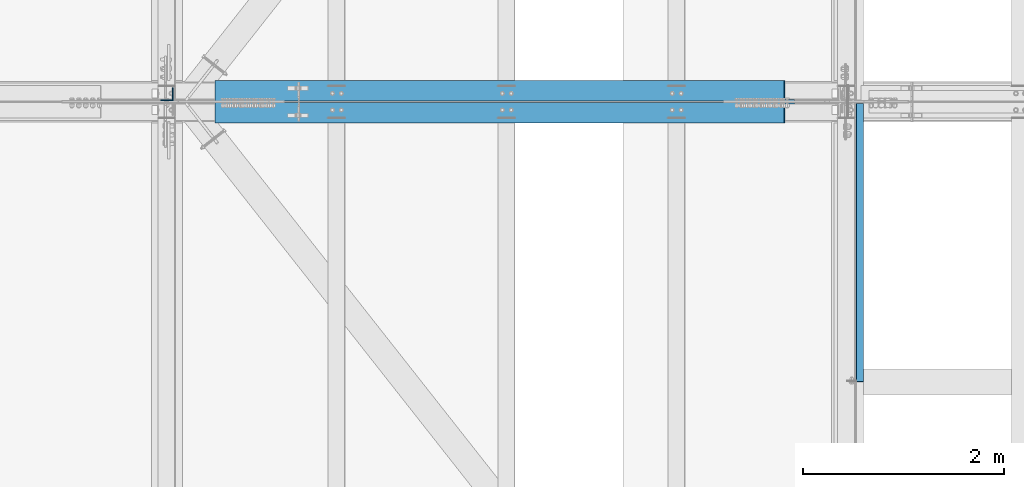
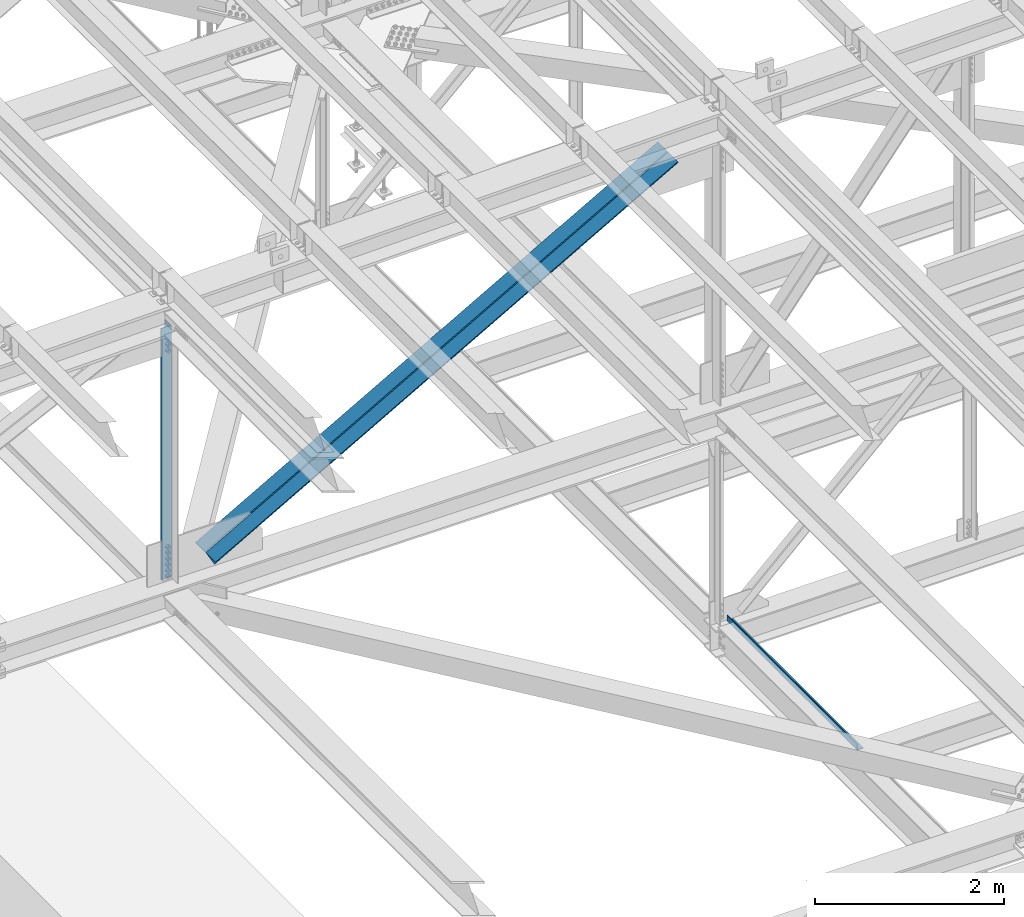
# One storey, part 1900 of 3843: 2 beams, 2 members, 4 elements without a shape of their own.
"""IFC2X3 building model written with IfcOpenShell, lengths in millimetres."""

from ifc_helpers import new_model, si_unit, frame, origin_with_axes, place, context, subcontext, project, spatial, faceted_brep, material, type_object, element, aggregate, save


model = new_model("IFC2X3")

# Units and contexts
model_context = context("Model", 3, precision=1e-05, world=origin_with_axes())
body_context = subcontext(model_context, "Body", "Model", "MODEL_VIEW")
ifc_project = project(units=[si_unit("LENGTHUNIT", "METRE", prefix="MILLI"), si_unit("AREAUNIT", "SQUARE_METRE"), si_unit("VOLUMEUNIT", "CUBIC_METRE"), si_unit("MASSUNIT", "GRAM", prefix="KILO"), si_unit("TIMEUNIT", "SECOND"), si_unit("PLANEANGLEUNIT", "RADIAN"), si_unit("SOLIDANGLEUNIT", "STERADIAN"), si_unit("THERMODYNAMICTEMPERATUREUNIT", "DEGREE_CELSIUS"), si_unit("LUMINOUSINTENSITYUNIT", "LUMEN")], contexts=[model_context])

# Site, building, storey
site_placement = place(None, origin_with_axes())
site = spatial("IfcSite", under=ifc_project, at=site_placement, CompositionType="ELEMENT")
building_placement = place(site_placement, origin_with_axes())
building = spatial("IfcBuilding", under=site, at=building_placement, Name="Undefined", CompositionType="ELEMENT")
storey_placement = place(building_placement, origin_with_axes())
storey = spatial("IfcBuildingStorey", under=building, at=storey_placement, Name="Undefined", CompositionType="ELEMENT", Elevation=0.0)

# Assembly, beam
assembly_1_placement = place(storey_placement, origin_with_axes())
assembly_1 = element("IfcElementAssembly", 1, at=assembly_1_placement, inside=storey, Name="BENT_PLATE", AssemblyPlace="NOTDEFINED", PredefinedType="RIGID_FRAME")
ifc_material_1 = material(Name="STEEL/A36")
beam_type_1 = type_object("IfcBeamType", PredefinedType="NOTDEFINED")
beam_1_placement = place(assembly_1_placement, frame((77179.4875000007, 65869.34475, 39627.1749999995), z_axis=(0.0, 1.0, 0.0), x_axis=(-1.0, 0.0, 0.0)))
beam_1 = element("IfcBeam", 2, at=beam_1_placement, type_object=beam_type_1, material=ifc_material_1, Name="BENT_PLATE", context=body_context, shape_type="Brep", body=[
    faceted_brep([(73.0250000006927, 0.0, -1382.7135), (69.8500000005442, 3.17500000000291, -1379.53850000001), (69.850000000617, 73.0249999994776, -1379.53850000001), (73.02500000078, 73.0249999994703, -1382.71249999999), (0.0, -7.27595761418343e-12, -1382.71249999999), (0.0, 3.17500000000291, -1379.53850000001), (69.8500000005442, 3.17500000000291, 1382.71249999999), (0.0, 3.17500000000291, 1382.71249999999), (0.0, -3.17500000000291, 1382.71249999999), (76.2000000005355, -3.17500000000291, 1382.71249999999), (76.2000000006228, 73.024999999463, 1382.71249999999), (69.850000000617, 73.0249999994776, 1382.71249999999), (0.0, -3.17500000000291, -1382.71249999999), (76.2000000005355, -3.17500000000291, -1382.71249999999), (76.2000000006228, 73.024999999463, -1382.71249999999)], [[[0, 1, 2, 3]], [[4, 5, 1, 0]], [[6, 7, 8, 9, 10, 11]], [[8, 12, 13, 9]], [[9, 13, 14, 10]], [[11, 10, 14, 3, 2]], [[6, 11, 2, 1]], [[7, 6, 1, 5]], [[12, 8, 7, 5, 4]], [[14, 13, 12, 4, 0, 3]]]),
])
aggregate(assembly_1, [beam_1])

assembly_2_placement = place(storey_placement, origin_with_axes())
assembly_2 = element("IfcElementAssembly", 3, at=assembly_2_placement, inside=storey, Name="ANGLE", AssemblyPlace="NOTDEFINED", PredefinedType="RIGID_FRAME")
ifc_material_2 = material(Name="STEEL/A572-50")
beam_type_2 = type_object("IfcBeamType", Name="L5X5X3/8", PredefinedType="NOTDEFINED")
beam_2_placement = place(assembly_2_placement, frame((70256.4000000248, 67344.925, 46031.6211476875), z_axis=(-1.0, 0.0, 0.0), x_axis=(0.0, 0.0, -1.0)))
beam_2 = element("IfcBeam", 4, at=beam_2_placement, type_object=beam_type_2, material=ifc_material_2, Name="ANGLE", ObjectType="L5X5X3/8", context=body_context, shape_type="Brep", body=[
    faceted_brep([(224.341645656066, 63.5, -63.5), (224.341645656066, 63.5, 63.5), (3477.81674516187, 63.5, 63.5), (3477.81674516187, 63.5, -63.5), (224.341645656066, 53.9750000000058, 63.5), (3477.81674516187, 53.9750000000058, 63.5), (224.341645656066, 53.9750000000058, -53.9750000000058), (3477.81674516187, 53.9750000000058, -53.9750000000058), (224.341645656066, -63.5, -53.9750000000058), (3477.81674516187, -63.5, -53.9750000000058), (224.341645656066, -63.5, -63.5), (3477.81674516187, -63.5, -63.5)], [[[0, 1, 2, 3]], [[1, 4, 5, 2]], [[4, 6, 7, 5]], [[6, 8, 9, 7]], [[8, 10, 11, 9]], [[10, 0, 3, 11]], [[5, 7, 9, 11, 3, 2]], [[10, 8, 6, 4, 1, 0]]]),
])
aggregate(assembly_2, [beam_2])

# Assembly, member
assembly_3_placement = place(storey_placement, origin_with_axes())
assembly_3 = element("IfcElementAssembly", 5, at=assembly_3_placement, inside=storey, Name="ANGLE", AssemblyPlace="NOTDEFINED", PredefinedType="RIGID_FRAME")
member_type = type_object("IfcMemberType", Name="L8X8X1/2", PredefinedType="NOTDEFINED")
member_1_placement = place(assembly_3_placement, frame((77012.8, 67383.025, 46168.1307216251), z_axis=(0.0, 1.0, 0.0), x_axis=(-0.87027971423951, 0.0, -0.492557833135558)))
member_1 = element("IfcMember", 6, at=member_1_placement, type_object=member_type, material=ifc_material_2, Name="ANGLE", ObjectType="L8X8X1/2", context=body_context, shape_type="Brep", body=[
    faceted_brep([(655.732975786857, 101.59999999575, -101.600000000006), (655.732975786857, 101.59999999575, 101.600000000006), (7160.10159466899, 101.599999955667, 101.600000000006), (7160.10159466899, 101.599999955667, -101.600000000006), (655.732975786974, 88.8999999957746, 101.600000000006), (7160.10159466912, 88.8999999556913, 101.600000000006), (655.732975786974, 88.8999999957746, -88.8999999999942), (7160.10159466912, 88.8999999556913, -88.8999999999942), (655.732975788866, -101.600000003833, -88.8999999999942), (7160.10159467101, -101.600000043916, -88.8999999999942), (655.732975788866, -101.600000003833, -101.600000000006), (7160.10159467101, -101.600000043916, -101.600000000006)], [[[0, 1, 2, 3]], [[1, 4, 5, 2]], [[4, 6, 7, 5]], [[6, 8, 9, 7]], [[8, 10, 11, 9]], [[10, 0, 3, 11]], [[5, 7, 9, 11, 3, 2]], [[10, 8, 6, 4, 1, 0]]]),
])
aggregate(assembly_3, [member_1])

assembly_4_placement = place(storey_placement, origin_with_axes())
assembly_4 = element("IfcElementAssembly", 7, at=assembly_4_placement, inside=storey, Name="ANGLE", AssemblyPlace="NOTDEFINED", PredefinedType="RIGID_FRAME")
member_2_placement = place(assembly_4_placement, frame((70256.4000025122, 67160.775, 42344.1673628749), z_axis=(0.0, -1.0, 0.0), x_axis=(0.870279714239512, 0.0, 0.492557833135555)))
member_2 = element("IfcMember", 8, at=member_2_placement, type_object=member_type, material=ifc_material_2, Name="ANGLE", ObjectType="L8X8X1/2", context=body_context, shape_type="Brep", body=[
    faceted_brep([(603.379370333947, 101.600000003505, -101.600000000006), (603.379370333947, 101.600000003505, 101.600000000006), (7107.74798921609, 101.600000043588, 101.600000000006), (7107.74798921609, 101.600000043588, -101.600000000006), (603.379370333801, 88.9000000035367, 101.600000000006), (7107.74798921596, 88.9000000436126, 101.600000000006), (603.379370333801, 88.9000000035367, -88.8999999999942), (7107.74798921596, 88.9000000436126, -88.8999999999942), (603.379370331924, -101.599999996078, -88.8999999999942), (7107.74798921407, -101.599999955994, -88.8999999999942), (603.379370331924, -101.599999996078, -101.600000000006), (7107.74798921407, -101.599999955994, -101.600000000006)], [[[0, 1, 2, 3]], [[1, 4, 5, 2]], [[4, 6, 7, 5]], [[6, 8, 9, 7]], [[8, 10, 11, 9]], [[10, 0, 3, 11]], [[5, 7, 9, 11, 3, 2]], [[10, 8, 6, 4, 1, 0]]]),
])
aggregate(assembly_4, [member_2])

save(model, "model.ifc")
